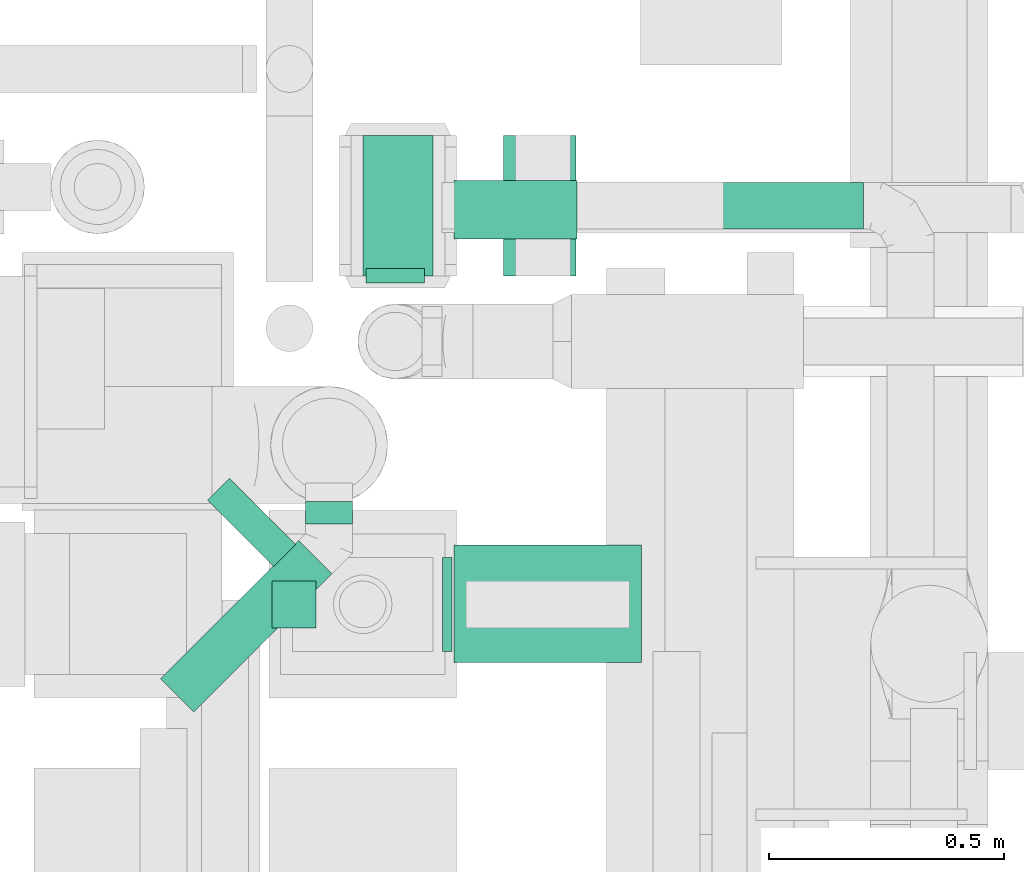
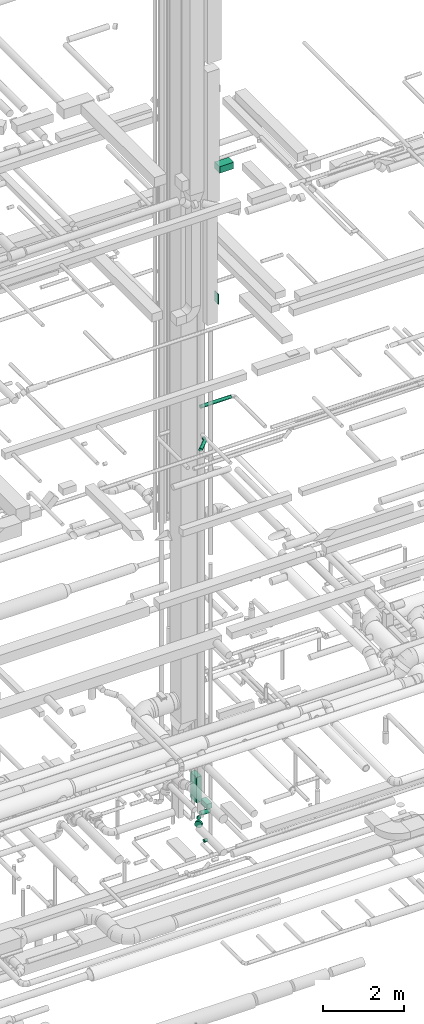
# One storey, part 235 of 337: 11 flow segments.
"""IFC2X3 building model written with IfcOpenShell, lengths in millimetres."""

from ifc_helpers import new_model, entity, si_unit, converted_unit, derived_unit, direction, frame, origin, origin_2d_with_axis, place, context, subcontext, project, spatial, rectangle, circle, extrude, type_object, element, save


model = new_model("IFC2X3")

# Units and contexts
model_context = context("Model", 3, precision=0.01, world=origin(), true_north=direction((6.12303176911189e-17, 1.0)))
body_context = subcontext(model_context, "Body", "Model", "MODEL_VIEW")
ifc_project = project(units=[si_unit("LENGTHUNIT", "METRE", prefix="MILLI"), si_unit("AREAUNIT", "SQUARE_METRE"), si_unit("VOLUMEUNIT", "CUBIC_METRE"), converted_unit("PLANEANGLEUNIT", "DEGREE", entity("IfcRatioMeasure", 0.0174532925199433), si_unit("PLANEANGLEUNIT", "RADIAN"), dimensions=[0, 0, 0, 0, 0, 0, 0]), si_unit("MASSUNIT", "GRAM", prefix="KILO"), derived_unit("MASSDENSITYUNIT", [(si_unit("MASSUNIT", "GRAM", prefix="KILO"), 1), (si_unit("LENGTHUNIT", "METRE"), -3)]), derived_unit("MOMENTOFINERTIAUNIT", [(si_unit("LENGTHUNIT", "METRE"), 4)]), si_unit("TIMEUNIT", "SECOND"), si_unit("FREQUENCYUNIT", "HERTZ"), si_unit("THERMODYNAMICTEMPERATUREUNIT", "DEGREE_CELSIUS"), derived_unit("THERMALTRANSMITTANCEUNIT", [(si_unit("MASSUNIT", "GRAM", prefix="KILO"), 1), (si_unit("THERMODYNAMICTEMPERATUREUNIT", "KELVIN"), -1), (si_unit("TIMEUNIT", "SECOND"), -3)]), derived_unit("VOLUMETRICFLOWRATEUNIT", [(si_unit("LENGTHUNIT", "METRE"), 3), (si_unit("TIMEUNIT", "SECOND"), -1)]), derived_unit("MASSFLOWRATEUNIT", [(si_unit("MASSUNIT", "GRAM", prefix="KILO"), 1), (si_unit("TIMEUNIT", "SECOND"), -1)]), derived_unit("ROTATIONALFREQUENCYUNIT", [(si_unit("TIMEUNIT", "SECOND"), -1)]), si_unit("ELECTRICCURRENTUNIT", "AMPERE"), si_unit("ELECTRICVOLTAGEUNIT", "VOLT"), si_unit("POWERUNIT", "WATT"), si_unit("FORCEUNIT", "NEWTON", prefix="KILO"), si_unit("ILLUMINANCEUNIT", "LUX"), si_unit("LUMINOUSFLUXUNIT", "LUMEN"), si_unit("LUMINOUSINTENSITYUNIT", "CANDELA"), derived_unit("USERDEFINED", [(si_unit("MASSUNIT", "GRAM", prefix="KILO"), -1), (si_unit("LENGTHUNIT", "METRE"), -2), (si_unit("TIMEUNIT", "SECOND"), 3), (si_unit("LUMINOUSFLUXUNIT", "LUMEN"), 1)]), derived_unit("LINEARVELOCITYUNIT", [(si_unit("LENGTHUNIT", "METRE"), 1), (si_unit("TIMEUNIT", "SECOND"), -1)]), si_unit("PRESSUREUNIT", "PASCAL"), derived_unit("USERDEFINED", [(si_unit("LENGTHUNIT", "METRE"), -2), (si_unit("MASSUNIT", "GRAM", prefix="KILO"), 1), (si_unit("TIMEUNIT", "SECOND"), -2)]), derived_unit("LINEARFORCEUNIT", [(si_unit("MASSUNIT", "GRAM", prefix="KILO"), 1), (si_unit("LENGTHUNIT", "METRE"), 1), (si_unit("TIMEUNIT", "SECOND"), -2), (si_unit("LENGTHUNIT", "METRE"), -1)]), derived_unit("PLANARFORCEUNIT", [(si_unit("MASSUNIT", "GRAM", prefix="KILO"), 1), (si_unit("LENGTHUNIT", "METRE"), 1), (si_unit("TIMEUNIT", "SECOND"), -2), (si_unit("LENGTHUNIT", "METRE"), -2)])], contexts=[model_context])

# Site, building, storey
site_placement = place(None, origin())
site = spatial("IfcSite", under=ifc_project, at=site_placement, CompositionType="ELEMENT")
building_placement = place(site_placement, origin())
building = spatial("IfcBuilding", under=site, at=building_placement, CompositionType="ELEMENT")
storey_placement = place(building_placement, origin())
storey = spatial("IfcBuildingStorey", under=building, at=storey_placement, CompositionType="ELEMENT", Elevation=0.0)

# Flow segments
duct_segment_type_1 = type_object("IfcDuctSegmentType", PredefinedType="NOTDEFINED")
flow_segment_1_placement = place(storey_placement, frame((59780.69, 11664.2, -625.0)))
element("IfcFlowSegment", 1, at=flow_segment_1_placement, inside=storey, type_object=duct_segment_type_1, context=body_context, shape_type="SweptSolid", body=[
    extrude(rectangle(XDim=154.584400000159, YDim=300.000000000001, at=origin_2d_with_axis()), frame((77.29, 150.0, 0.0), z_axis=(0.0, 0.0, 1.0), x_axis=(-1.0, 0.0, 0.0)), (0.0, 0.0, 1.0), 150.0),
])
flow_segment_2_placement = place(storey_placement, frame((59480.69, 11664.2, -325.0)))
element("IfcFlowSegment", 2, at=flow_segment_2_placement, inside=storey, type_object=duct_segment_type_1, context=body_context, shape_type="SweptSolid", body=[
    extrude(rectangle(XDim=150.000000000001, YDim=299.999999999999, at=origin_2d_with_axis()), frame((75.0, 150.0, 0.0), z_axis=(0.0, 0.0, 1.0), x_axis=(-1.0, 0.0, 0.0)), (0.0, 0.0, 1.0), 775.000000000065),
])
flow_segment_3_placement = place(storey_placement, frame((59650.56, 10864.63, 15200.0)))
element("IfcFlowSegment", 3, at=flow_segment_3_placement, inside=storey, type_object=duct_segment_type_1, context=body_context, shape_type="SweptSolid", body=[
    extrude(rectangle(XDim=20.0000000000214, YDim=200.0, at=origin_2d_with_axis()), frame((10.0, 100.0, 0.0)), (0.0, 0.0, 1.0), 300.000000000001),
])
flow_segment_4_placement = place(storey_placement, frame((59675.56, 10840.63, 19175.0)))
element("IfcFlowSegment", 4, at=flow_segment_4_placement, inside=storey, type_object=duct_segment_type_1, context=body_context, shape_type="SweptSolid", body=[
    extrude(rectangle(XDim=399.279637609056, YDim=249.999999999999, at=origin_2d_with_axis()), frame((199.64, 125.0, 0.0), z_axis=(0.0, 0.0, 1.0), x_axis=(-1.0, 0.0, 0.0)), (0.0, 0.0, 1.0), 199.999999999998),
])
duct_segment_type_2 = type_object("IfcDuctSegmentType", PredefinedType="NOTDEFINED")
flow_segment_5_placement = place(storey_placement, frame((59485.9, 11649.89, -849.1)))
element("IfcFlowSegment", 5, at=flow_segment_5_placement, inside=storey, type_object=duct_segment_type_2, context=body_context, shape_type="SweptSolid", body=[
    extrude(circle(Radius=62.5, at=origin_2d_with_axis()), frame((64.1, 0.0, 64.1), z_axis=(-2.77012810696602e-07, 1.0, 0.0), x_axis=(1.0, 2.77012810696602e-07, 0.0)), (0.0, 0.0, 1.0), 30.9741654758862),
])
flow_segment_6_placement = place(storey_placement, frame((59674.99, 11741.77, -849.1)))
element("IfcFlowSegment", 6, at=flow_segment_6_placement, inside=storey, type_object=duct_segment_type_2, context=body_context, shape_type="SweptSolid", body=[
    extrude(circle(Radius=62.5, at=origin_2d_with_axis()), frame((0.0, 64.1, 64.1), z_axis=(1.0, 0.0, 0.0), x_axis=(0.0, -1.0, 0.0)), (0.0, 0.0, 1.0), 262.660841981736),
])
flow_segment_7_placement = place(storey_placement, frame((59148.28, 11043.53, -651.6)))
element("IfcFlowSegment", 7, at=flow_segment_7_placement, inside=storey, type_object=duct_segment_type_2, context=body_context, shape_type="SweptSolid", body=[
    extrude(circle(Radius=100.0, at=origin_2d_with_axis()), frame((72.31, 72.31, 101.6), z_axis=(0.707106781186531, 0.707106781186564, 0.0), x_axis=(0.707106781186564, -0.707106781186531, 0.0)), (0.0, 0.0, 1.0), 66.3677979742427),
])
flow_segment_8_placement = place(storey_placement, frame((59286.81, 10913.04, -1026.6)))
element("IfcFlowSegment", 8, at=flow_segment_8_placement, inside=storey, type_object=duct_segment_type_2, context=body_context, shape_type="SweptSolid", body=[
    extrude(circle(Radius=50.0, at=origin_2d_with_axis()), frame((0.0, 51.6, 51.6), z_axis=(1.0, 0.0, 0.0), x_axis=(0.0, 1.0, 0.0)), (0.0, 0.0, 1.0), 93.7471300001388),
])
flow_segment_9_placement = place(storey_placement, frame((59675.69, 11762.61, 11468.4)))
element("IfcFlowSegment", 9, at=flow_segment_9_placement, inside=storey, type_object=duct_segment_type_2, context=body_context, shape_type="SweptSolid", body=[
    extrude(circle(Radius=50.0, at=origin_2d_with_axis()), frame((0.0, 51.6, 51.6), z_axis=(1.0, 0.0, 0.0), x_axis=(0.0, 1.0, 0.0)), (0.0, 0.0, 1.0), 872.01727579195),
])
flow_segment_10_placement = place(storey_placement, frame((59357.34, 11135.64, 10998.4)))
element("IfcFlowSegment", 10, at=flow_segment_10_placement, inside=storey, type_object=duct_segment_type_2, context=body_context, shape_type="SweptSolid", body=[
    extrude(circle(Radius=50.0, at=origin_2d_with_axis()), frame((51.6, 0.0, 51.6), z_axis=(0.0, 1.0, 0.0), x_axis=(1.0, 0.0, 0.0)), (0.0, 0.0, 1.0), 48.5384485589837),
])
flow_segment_11_placement = place(storey_placement, frame((59048.12, 10733.41, 10998.4)))
element("IfcFlowSegment", 11, at=flow_segment_11_placement, inside=storey, type_object=duct_segment_type_2, context=body_context, shape_type="SweptSolid", body=[
    extrude(circle(Radius=50.0, at=origin_2d_with_axis()), frame((36.95, 36.95, 51.6), z_axis=(0.707106781186579, 0.707106781186516, 0.0), x_axis=(-0.707106781186516, 0.707106781186579, 0.0)), (0.0, 0.0, 1.0), 416.595233009736),
])

save(model, "model.ifc")
